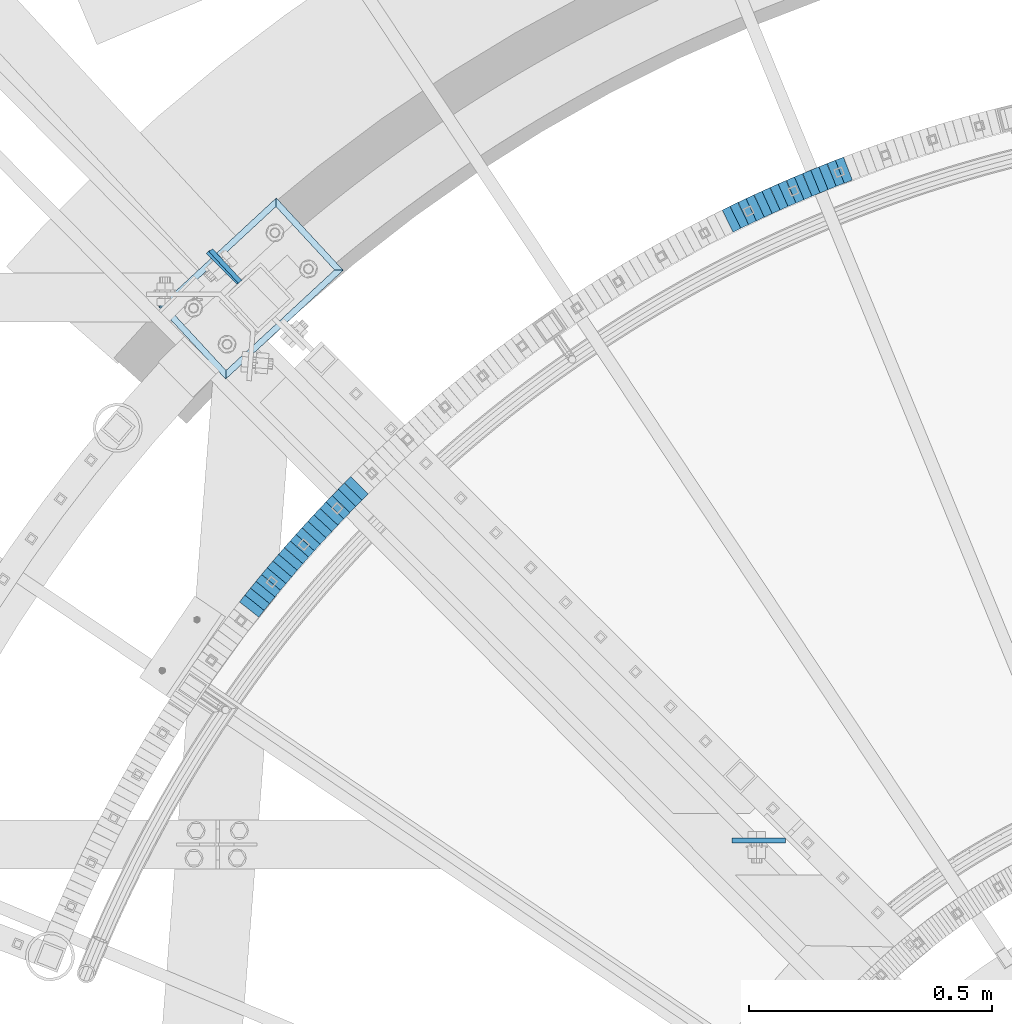
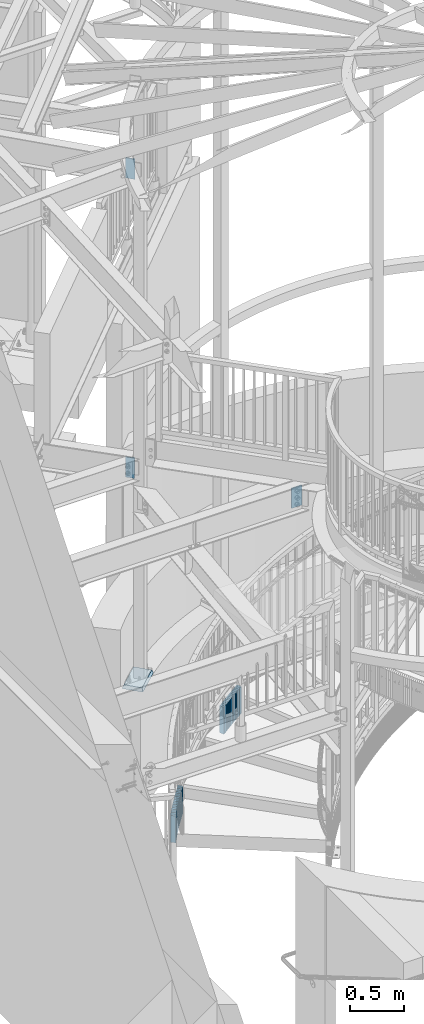
# One storey, part 892 of 975: 38 plates.
"""IFC2X3 building model written with IfcOpenShell, lengths in millimetres."""

from ifc_helpers import new_model, si_unit, frame, origin_with_axes, place, context, subcontext, project, spatial, faceted_brep, material, type_object, element, save


model = new_model("IFC2X3")

# Units and contexts
model_context = context("Model", 3, precision=1e-05, world=origin_with_axes())
body_context = subcontext(model_context, "Body", "Model", "MODEL_VIEW")
ifc_project = project(units=[si_unit("LENGTHUNIT", "METRE", prefix="MILLI"), si_unit("AREAUNIT", "SQUARE_METRE"), si_unit("VOLUMEUNIT", "CUBIC_METRE"), si_unit("MASSUNIT", "GRAM", prefix="KILO"), si_unit("TIMEUNIT", "SECOND"), si_unit("PLANEANGLEUNIT", "RADIAN"), si_unit("SOLIDANGLEUNIT", "STERADIAN"), si_unit("THERMODYNAMICTEMPERATUREUNIT", "DEGREE_CELSIUS"), si_unit("LUMINOUSINTENSITYUNIT", "LUMEN")], contexts=[model_context])

# Site, building, storey
site_placement = place(None, origin_with_axes())
site = spatial("IfcSite", under=ifc_project, at=site_placement, CompositionType="ELEMENT")
building_placement = place(site_placement, origin_with_axes())
building = spatial("IfcBuilding", under=site, at=building_placement, Name="Undefined", CompositionType="ELEMENT")
storey_placement = place(building_placement, origin_with_axes())
storey = spatial("IfcBuildingStorey", under=building, at=storey_placement, Name="Undefined", CompositionType="ELEMENT", Elevation=0.0)

# Plates
ifc_material_1 = material(Name="STEEL/A36")
plate_type_1 = type_object("IfcPlateType", PredefinedType="NOTDEFINED")
plate_1_placement = place(storey_placement, frame((33694.2841513362, 6079.05078259867, 728.399999991737), z_axis=(0.931899909597925, 0.362715533843505, 0.0), x_axis=(0.0, 0.0, -1.0)))
element("IfcPlate", 1, at=plate_1_placement, inside=storey, type_object=plate_type_1, material=ifc_material_1, Name="WALL", context=body_context, shape_type="Brep", body=[
    faceted_brep([(0.0, -25.3999999999724, -1.81898940354586e-11), (-5.80000019073486, -25.3999999999724, 17.9212169647508), (-5.80000019073486, 25.399999999885, 17.9212169646526), (0.0, 25.3999999999869, 1.45519152283669e-11), (299.0, -25.3999999999724, 17.9212169647508), (299.0, 25.399999999885, 17.9212169646526), (304.799987792969, -25.3999999999724, -1.81898940354586e-11), (304.799987792969, 25.3999999999869, 1.45519152283669e-11)], [[[0, 1, 2, 3]], [[1, 4, 5, 2]], [[4, 6, 7, 5]], [[6, 0, 3, 7]], [[5, 7, 3, 2]], [[6, 4, 1, 0]]]),
])
plate_2_placement = place(storey_placement, frame((33677.5841513301, 6072.55078259968, 722.699999991737), z_axis=(0.931899909597925, 0.362715533843505, 0.0), x_axis=(0.0, 0.0, -1.0)))
element("IfcPlate", 2, at=plate_2_placement, inside=storey, type_object=plate_type_1, material=ifc_material_1, Name="WALL", context=body_context, shape_type="Brep", body=[
    faceted_brep([(0.0, -25.3999999999724, -1.81898940354586e-11), (-5.69999980926514, -25.4000000000087, 17.9245643615468), (-5.69999980926514, 25.3999999999687, 17.9245643615541), (0.0, 25.3999999999869, 1.45519152283669e-11), (299.100006103516, -25.4000000000087, 17.9245643615468), (299.100006103516, 25.3999999999687, 17.9245643615541), (304.799987792969, -25.3999999999724, -1.81898940354586e-11), (304.799987792969, 25.3999999999869, 1.45519152283669e-11)], [[[0, 1, 2, 3]], [[1, 4, 5, 2]], [[4, 6, 7, 5]], [[6, 0, 3, 7]], [[5, 7, 3, 2]], [[6, 4, 1, 0]]]),
])
plate_3_placement = place(storey_placement, frame((33660.6904567118, 6065.73436197421, 716.999999991737), z_axis=(0.927316420402317, 0.374278314162379, 0.0), x_axis=(0.0, 0.0, -1.0)))
element("IfcPlate", 3, at=plate_3_placement, inside=storey, type_object=plate_type_1, material=ifc_material_1, Name="WALL", context=body_context, shape_type="Brep", body=[
    faceted_brep([(0.0, -25.3999999999724, -1.81898940354586e-11), (-5.69999980926514, -25.3999999999578, 17.9047489166387), (-5.69999980926514, 25.3999999999069, 17.9047489165732), (0.0, 25.3999999999869, 1.45519152283669e-11), (299.100006103516, -25.3999999999578, 17.9047489166387), (299.100006103516, 25.3999999999069, 17.9047489165732), (304.799987792969, -25.3999999999724, -1.81898940354586e-11), (304.799987792969, 25.3999999999869, 1.45519152283669e-11)], [[[0, 1, 2, 3]], [[1, 4, 5, 2]], [[4, 6, 7, 5]], [[6, 0, 3, 7]], [[5, 7, 3, 2]], [[6, 4, 1, 0]]]),
])
for number, where, z_axis, x_axis, name in (
    (4, (33643.9688259892, 6058.88490408454, 711.199999991737), (0.925369259401996, 0.379066925164674, 0.0), (0.0, 0.0, -1.0), "WALL"),
    (5, (33627.3688259861, 6052.08490408421, 705.399999991737), (0.925369259401996, 0.379066925164674, 0.0), (0.0, 0.0, -1.0), "WALL"),
):
    element("IfcPlate", number, at=place(storey_placement, frame(where, z_axis=z_axis, x_axis=x_axis)), inside=storey, type_object=plate_type_1, material=ifc_material_1, Name=name, context=body_context, shape_type="Brep", body=[
        faceted_brep([(0.0, -25.3999999999724, -1.81898940354586e-11), (-5.80000019073486, -25.3999999999869, 17.9387855530222), (-5.80000019073486, 25.3999999999469, 17.9387855528548), (0.0, 25.3999999999869, 1.45519152283669e-11), (299.0, -25.3999999999869, 17.9387855530222), (299.0, 25.3999999999469, 17.9387855528548), (304.799987792969, -25.3999999999724, -1.81898940354586e-11), (304.799987792969, 25.3999999999869, 1.45519152283669e-11)], [[[0, 1, 2, 3]], [[1, 4, 5, 2]], [[4, 6, 7, 5]], [[6, 0, 3, 7]], [[5, 7, 3, 2]], [[6, 4, 1, 0]]]),
    ])
for number, where, z_axis, x_axis, name in (
    (6, (33610.5771597716, 6044.96330215377, 699.699999991737), (0.920581781842572, 0.390549846933213, 0.0), (0.0, 0.0, -1.0), "WALL"),
    (7, (33594.0771597699, 6037.96330215338, 693.999999991737), (0.920581781842572, 0.390549846933213, 0.0), (0.0, 0.0, -1.0), "WALL"),
):
    element("IfcPlate", number, at=place(storey_placement, frame(where, z_axis=z_axis, x_axis=x_axis)), inside=storey, type_object=plate_type_1, material=ifc_material_1, Name=name, context=body_context, shape_type="Brep", body=[
        faceted_brep([(0.0, -25.3999999999724, -1.81898940354586e-11), (-5.69999980926514, -25.4000000000087, 17.9245643615468), (-5.69999980926514, 25.3999999999687, 17.9245643615541), (0.0, 25.3999999999869, 1.45519152283669e-11), (299.100006103516, -25.4000000000087, 17.9245643615468), (299.100006103516, 25.3999999999687, 17.9245643615541), (304.799987792969, -25.3999999999724, -1.81898940354586e-11), (304.799987792969, 25.3999999999869, 1.45519152283669e-11)], [[[0, 1, 2, 3]], [[1, 4, 5, 2]], [[4, 6, 7, 5]], [[6, 0, 3, 7]], [[5, 7, 3, 2]], [[6, 4, 1, 0]]]),
    ])
plate_4_placement = place(storey_placement, frame((33577.3865783012, 6030.63788326108, 688.199999991737), z_axis=(0.915644030049762, 0.401990062357556, -1.95650045498041e-10), x_axis=(0.0, 0.0, -1.0)))
element("IfcPlate", 8, at=plate_4_placement, inside=storey, type_object=plate_type_1, material=ifc_material_1, Name="WALL", context=body_context, shape_type="Brep", body=[
    faceted_brep([(0.0, -25.3999999999724, -1.81898940354586e-11), (-5.80000019073486, -25.4000000000415, 17.9067020416005), (-5.80000019073486, 25.3999999999396, 17.9067020415678), (0.0, 25.3999999999869, 1.45519152283669e-11), (299.0, -25.4000000000415, 17.9067020416005), (299.0, 25.3999999999396, 17.9067020415678), (304.799987792969, -25.3999999999724, -1.81898940354586e-11), (304.799987792969, 25.3999999999869, 1.45519152283669e-11)], [[[0, 1, 2, 3]], [[1, 4, 5, 2]], [[4, 6, 7, 5]], [[6, 0, 3, 7]], [[5, 7, 3, 2]], [[6, 4, 1, 0]]]),
])
plate_5_placement = place(storey_placement, frame((33560.9865782972, 6023.43788326146, 682.499999991737), z_axis=(0.915644030049762, 0.401990062357556, -1.95650045498041e-10), x_axis=(0.0, 0.0, -1.0)))
element("IfcPlate", 9, at=plate_5_placement, inside=storey, type_object=plate_type_1, material=ifc_material_1, Name="WALL", context=body_context, shape_type="Brep", body=[
    faceted_brep([(0.0, -25.3999999999724, -1.81898940354586e-11), (-5.69999980926514, -25.4000000000524, 17.9134025573221), (-5.69999980926514, 25.4000000000524, 17.9134025574494), (0.0, 25.3999999999869, 1.45519152283669e-11), (299.100006103516, -25.4000000000524, 17.9134025573221), (299.100006103516, 25.4000000000524, 17.9134025574494), (304.799987792969, -25.3999999999724, -1.81898940354586e-11), (304.799987792969, 25.3999999999869, 1.45519152283669e-11)], [[[0, 1, 2, 3]], [[1, 4, 5, 2]], [[4, 6, 7, 5]], [[6, 0, 3, 7]], [[5, 7, 3, 2]], [[6, 4, 1, 0]]]),
])
plate_6_placement = place(storey_placement, frame((33544.3972225924, 6015.90869021668, 676.699999991737), z_axis=(0.910557689794828, 0.413382018906854, 0.0), x_axis=(0.0, 0.0, -1.0)))
element("IfcPlate", 10, at=plate_6_placement, inside=storey, type_object=plate_type_1, material=ifc_material_1, Name="WALL", context=body_context, shape_type="Brep", body=[
    faceted_brep([(0.0, -25.3999999999724, -1.81898940354586e-11), (-5.80000019073486, -25.3999999999614, 17.8966484070224), (-5.80000019073486, 25.3999999999105, 17.896648406906), (0.0, 25.3999999999869, 1.45519152283669e-11), (299.0, -25.3999999999614, 17.8966484070224), (299.0, 25.3999999999105, 17.896648406906), (304.799987792969, -25.3999999999724, -1.81898940354586e-11), (304.799987792969, 25.3999999999869, 1.45519152283669e-11)], [[[0, 1, 2, 3]], [[1, 4, 5, 2]], [[4, 6, 7, 5]], [[6, 0, 3, 7]], [[5, 7, 3, 2]], [[6, 4, 1, 0]]]),
])
plate_7_placement = place(storey_placement, frame((33528.1435691843, 6008.48425708857, 670.999999991737), z_axis=(0.909595755817756, 0.415494357360392, 3.29607246385422e-10), x_axis=(0.0, 0.0, -1.0)))
element("IfcPlate", 11, at=plate_7_placement, inside=storey, type_object=plate_type_1, material=ifc_material_1, Name="WALL", context=body_context, shape_type="Brep", body=[
    faceted_brep([(0.0, -25.3999999999724, -1.81898940354586e-11), (-5.69999980926514, -25.4000000001106, 17.8134784697704), (-5.69999980926514, 25.4000000000306, 17.8134784698614), (0.0, 25.3999999999869, 1.45519152283669e-11), (299.100006103516, -25.4000000001106, 17.8134784697704), (299.100006103516, 25.4000000000306, 17.8134784698614), (304.799987792969, -25.3999999999724, -1.81898940354586e-11), (304.799987792969, 25.3999999999869, 1.45519152283669e-11)], [[[0, 1, 2, 3]], [[1, 4, 5, 2]], [[4, 6, 7, 5]], [[6, 0, 3, 7]], [[5, 7, 3, 2]], [[6, 4, 1, 0]]]),
])
plate_8_placement = place(storey_placement, frame((33511.709232515, 6000.77577129134, 665.299999991737), z_axis=(0.905324661295672, 0.424720211021181, 6.89760781824589e-11), x_axis=(0.0, 0.0, -1.0)))
element("IfcPlate", 12, at=plate_8_placement, inside=storey, type_object=plate_type_1, material=ifc_material_1, Name="WALL", context=body_context, shape_type="Brep", body=[
    faceted_brep([(0.0, -25.3999999999724, -1.81898940354586e-11), (-5.69999980926514, -25.4000000000087, 17.8910598754701), (-5.69999980926514, 25.4000000000087, 17.8910598755028), (0.0, 25.3999999999869, 1.45519152283669e-11), (299.100006103516, -25.4000000000087, 17.8910598754701), (299.100006103516, 25.4000000000087, 17.8910598755028), (304.799987792969, -25.3999999999724, -1.81898940354586e-11), (304.799987792969, 25.3999999999869, 1.45519152283669e-11)], [[[0, 1, 2, 3]], [[1, 4, 5, 2]], [[4, 6, 7, 5]], [[6, 0, 3, 7]], [[5, 7, 3, 2]], [[6, 4, 1, 0]]]),
])
plate_9_placement = place(storey_placement, frame((33495.5092325195, 5993.17577129076, 659.499999991737), z_axis=(0.905324661295672, 0.424720211021181, 6.89760781824589e-11), x_axis=(0.0, 0.0, -1.0)))
element("IfcPlate", 13, at=plate_9_placement, inside=storey, type_object=plate_type_1, material=ifc_material_1, Name="WALL", context=body_context, shape_type="Brep", body=[
    faceted_brep([(0.0, -25.3999999999724, -1.81898940354586e-11), (-5.80000019073486, -25.4000000000378, 17.8932952880568), (-5.80000019073486, 25.4000000001179, 17.8932952881351), (0.0, 25.3999999999869, 1.45519152283669e-11), (299.0, -25.4000000000378, 17.8932952880568), (299.0, 25.4000000001179, 17.8932952881351), (304.799987792969, -25.3999999999724, -1.81898940354586e-11), (304.799987792969, 25.3999999999869, 1.45519152283669e-11)], [[[0, 1, 2, 3]], [[1, 4, 5, 2]], [[4, 6, 7, 5]], [[6, 0, 3, 7]], [[5, 7, 3, 2]], [[6, 4, 1, 0]]]),
])
plate_10_placement = place(storey_placement, frame((33479.1227463276, 5985.23918009355, 653.799999991737), z_axis=(0.899947055070276, 0.435999195034048, 0.0), x_axis=(0.0, 0.0, -1.0)))
element("IfcPlate", 14, at=plate_10_placement, inside=storey, type_object=plate_type_1, material=ifc_material_1, Name="WALL", context=body_context, shape_type="Brep", body=[
    faceted_brep([(0.0, -25.3999999999724, -1.81898940354586e-11), (-5.69999980926514, -25.4000000000087, 17.8910598754701), (-5.69999980926514, 25.4000000000087, 17.8910598755028), (0.0, 25.3999999999869, 1.45519152283669e-11), (299.100006103516, -25.4000000000087, 17.8910598754701), (299.100006103516, 25.4000000000087, 17.8910598755028), (304.799987792969, -25.3999999999724, -1.81898940354586e-11), (304.799987792969, 25.3999999999869, 1.45519152283669e-11)], [[[0, 1, 2, 3]], [[1, 4, 5, 2]], [[4, 6, 7, 5]], [[6, 0, 3, 7]], [[5, 7, 3, 2]], [[6, 4, 1, 0]]]),
])
plate_11_placement = place(storey_placement, frame((33463.066788802, 5977.41198556887, 648.099999991737), z_axis=(0.898876404534364, 0.438202247108996, 8.72196324053222e-11), x_axis=(0.0, 0.0, -1.0)))
element("IfcPlate", 15, at=plate_11_placement, inside=storey, type_object=plate_type_1, material=ifc_material_1, Name="WALL", context=body_context, shape_type="Brep", body=[
    faceted_brep([(0.0, -25.3999999999724, -1.81898940354586e-11), (-5.69999980926514, -25.4000000000378, 17.8044929504049), (-5.69999980926514, 25.4000000000233, 17.8044929504613), (0.0, 25.3999999999869, 1.45519152283669e-11), (299.100006103516, -25.4000000000378, 17.8044929504049), (299.100006103516, 25.4000000000233, 17.8044929504613), (304.799987792969, -25.3999999999724, -1.81898940354586e-11), (304.799987792969, 25.3999999999869, 1.45519152283669e-11)], [[[0, 1, 2, 3]], [[1, 4, 5, 2]], [[4, 6, 7, 5]], [[6, 0, 3, 7]], [[5, 7, 3, 2]], [[6, 4, 1, 0]]]),
])
plate_12_placement = place(storey_placement, frame((32691.4366136415, 5420.04103714326, 344.099999991737), z_axis=(0.707106781186548, 0.707106781186548, 0.0), x_axis=(0.0, 0.0, -1.0)))
element("IfcPlate", 16, at=plate_12_placement, inside=storey, type_object=plate_type_1, material=ifc_material_1, Name="WALL", context=body_context, shape_type="Brep", body=[
    faceted_brep([(0.0, -25.3999999999724, -1.81898940354586e-11), (-5.69999980926514, -25.3999999999905, 17.9605121612622), (-5.69999980926514, 25.3999999999542, 17.9605121611967), (0.0, 25.3999999999869, 1.45519152283669e-11), (299.100006103516, -25.3999999999905, 17.9605121612622), (299.100006103516, 25.3999999999542, 17.9605121611967), (304.799987792969, -25.3999999999724, -1.81898940354586e-11), (304.799987792969, 25.3999999999869, 1.45519152283669e-11)], [[[0, 1, 2, 3]], [[1, 4, 5, 2]], [[4, 6, 7, 5]], [[6, 0, 3, 7]], [[5, 7, 3, 2]], [[6, 4, 1, 0]]]),
])
plate_13_placement = place(storey_placement, frame((32678.7249206485, 5407.02681907499, 338.399999991737), z_axis=(0.698672999098481, 0.715441150850812, -5.66315065952948e-11), x_axis=(0.0, 0.0, -1.0)))
element("IfcPlate", 17, at=plate_13_placement, inside=storey, type_object=plate_type_1, material=ifc_material_1, Name="WALL", context=body_context, shape_type="Brep", body=[
    faceted_brep([(0.0, -25.3999999999724, -1.81898940354586e-11), (-5.69999980926514, -25.4000000000087, 17.8910598754701), (-5.69999980926514, 25.4000000000087, 17.8910598755028), (0.0, 25.3999999999869, 1.45519152283669e-11), (299.100006103516, -25.4000000000087, 17.8910598754701), (299.100006103516, 25.4000000000087, 17.8910598755028), (304.799987792969, -25.3999999999724, -1.81898940354586e-11), (304.799987792969, 25.3999999999869, 1.45519152283669e-11)], [[[0, 1, 2, 3]], [[1, 4, 5, 2]], [[4, 6, 7, 5]], [[6, 0, 3, 7]], [[5, 7, 3, 2]], [[6, 4, 1, 0]]]),
])
plate_14_placement = place(storey_placement, frame((32666.224920648, 5394.22681907493, 332.599999991737), z_axis=(0.698672999098481, 0.715441150850812, -5.66315065952948e-11), x_axis=(0.0, 0.0, -1.0)))
element("IfcPlate", 18, at=plate_14_placement, inside=storey, type_object=plate_type_1, material=ifc_material_1, Name="WALL", context=body_context, shape_type="Brep", body=[
    faceted_brep([(0.0, -25.3999999999724, -1.81898940354586e-11), (-5.80000019073486, -25.4000000000378, 17.8932952880568), (-5.80000019073486, 25.4000000001179, 17.8932952881351), (0.0, 25.3999999999869, 1.45519152283669e-11), (299.0, -25.4000000000378, 17.8932952880568), (299.0, 25.4000000001179, 17.8932952881351), (304.799987792969, -25.3999999999724, -1.81898940354586e-11), (304.799987792969, 25.3999999999869, 1.45519152283669e-11)], [[[0, 1, 2, 3]], [[1, 4, 5, 2]], [[4, 6, 7, 5]], [[6, 0, 3, 7]], [[5, 7, 3, 2]], [[6, 4, 1, 0]]]),
])
plate_15_placement = place(storey_placement, frame((32653.6852384961, 5381.18264921557, 326.899999991737), z_axis=(0.692997020219925, 0.720940448280095, 1.13263922685292e-11), x_axis=(0.0, 0.0, -1.0)))
element("IfcPlate", 19, at=plate_15_placement, inside=storey, type_object=plate_type_1, material=ifc_material_1, Name="WALL", context=body_context, shape_type="Brep", body=[
    faceted_brep([(0.0, -25.3999999999724, -1.81898940354586e-11), (-5.69999980926514, -25.4000000000087, 17.8910598754701), (-5.69999980926514, 25.4000000000087, 17.8910598755028), (0.0, 25.3999999999869, 1.45519152283669e-11), (299.100006103516, -25.4000000000087, 17.8910598754701), (299.100006103516, 25.4000000000087, 17.8910598755028), (304.799987792969, -25.3999999999724, -1.81898940354586e-11), (304.799987792969, 25.3999999999869, 1.45519152283669e-11)], [[[0, 1, 2, 3]], [[1, 4, 5, 2]], [[4, 6, 7, 5]], [[6, 0, 3, 7]], [[5, 7, 3, 2]], [[6, 4, 1, 0]]]),
])
plate_16_placement = place(storey_placement, frame((32641.2467431682, 5368.03742547699, 321.099999991737), z_axis=(0.68727955022236, 0.726393020235017, 0.0), x_axis=(0.0, 0.0, -1.0)))
element("IfcPlate", 20, at=plate_16_placement, inside=storey, type_object=plate_type_1, material=ifc_material_1, Name="WALL", context=body_context, shape_type="Brep", body=[
    faceted_brep([(0.0, -25.3999999999724, -1.81898940354586e-11), (-5.80000019073486, -25.3999999999614, 17.8966484070224), (-5.80000019073486, 25.3999999999105, 17.896648406906), (0.0, 25.3999999999869, 1.45519152283669e-11), (299.0, -25.3999999999614, 17.8966484070224), (299.0, 25.3999999999105, 17.896648406906), (304.799987792969, -25.3999999999724, -1.81898940354586e-11), (304.799987792969, 25.3999999999869, 1.45519152283669e-11)], [[[0, 1, 2, 3]], [[1, 4, 5, 2]], [[4, 6, 7, 5]], [[6, 0, 3, 7]], [[5, 7, 3, 2]], [[6, 4, 1, 0]]]),
])
plate_17_placement = place(storey_placement, frame((32628.9094592778, 5354.79117625392, 315.399999991737), z_axis=(0.681521706462616, 0.73179789807042, 1.42966655403143e-10), x_axis=(0.0, 0.0, -1.0)))
element("IfcPlate", 21, at=plate_17_placement, inside=storey, type_object=plate_type_1, material=ifc_material_1, Name="WALL", context=body_context, shape_type="Brep", body=[
    faceted_brep([(0.0, -25.3999999999724, -1.81898940354586e-11), (-5.69999980926514, -25.3999999999578, 17.9047489166387), (-5.69999980926514, 25.3999999999069, 17.9047489165732), (0.0, 25.3999999999869, 1.45519152283669e-11), (299.100006103516, -25.3999999999578, 17.9047489166387), (299.100006103516, 25.3999999999069, 17.9047489165732), (304.799987792969, -25.3999999999724, -1.81898940354586e-11), (304.799987792969, 25.3999999999869, 1.45519152283669e-11)], [[[0, 1, 2, 3]], [[1, 4, 5, 2]], [[4, 6, 7, 5]], [[6, 0, 3, 7]], [[5, 7, 3, 2]], [[6, 4, 1, 0]]]),
])
plate_18_placement = place(storey_placement, frame((32616.7385799653, 5341.61475433813, 309.699999991737), z_axis=(0.678512969955015, 0.734588421909048, -9.16134013095869e-12), x_axis=(0.0, 0.0, -1.0)))
element("IfcPlate", 22, at=plate_18_placement, inside=storey, type_object=plate_type_1, material=ifc_material_1, Name="WALL", context=body_context, shape_type="Brep", body=[
    faceted_brep([(0.0, -25.3999999999724, -1.81898940354586e-11), (-5.69999980926514, -25.4000000000524, 17.8331146239652), (-5.69999980926514, 25.4000000000742, 17.8331146240998), (0.0, 25.3999999999869, 1.45519152283669e-11), (299.100006103516, -25.4000000000524, 17.8331146239652), (299.100006103516, 25.4000000000742, 17.8331146240998), (304.799987792969, -25.3999999999724, -1.81898940354586e-11), (304.799987792969, 25.3999999999869, 1.45519152283669e-11)], [[[0, 1, 2, 3]], [[1, 4, 5, 2]], [[4, 6, 7, 5]], [[6, 0, 3, 7]], [[5, 7, 3, 2]], [[6, 4, 1, 0]]]),
])
plate_19_placement = place(storey_placement, frame((32604.5734107281, 5328.3439304751, 303.899999991737), z_axis=(0.675724628076021, 0.737154140605289, 3.47004515788284e-10), x_axis=(0.0, 0.0, -1.0)))
element("IfcPlate", 23, at=plate_19_placement, inside=storey, type_object=plate_type_1, material=ifc_material_1, Name="WALL", context=body_context, shape_type="Brep", body=[
    faceted_brep([(0.0, -25.3999999999724, -1.81898940354586e-11), (-5.80000019073486, -25.4000000000415, 17.9067020416005), (-5.80000019073486, 25.3999999999396, 17.9067020415678), (0.0, 25.3999999999869, 1.45519152283669e-11), (299.0, -25.4000000000415, 17.9067020416005), (299.0, 25.3999999999396, 17.9067020415678), (304.799987792969, -25.3999999999724, -1.81898940354586e-11), (304.799987792969, 25.3999999999869, 1.45519152283669e-11)], [[[0, 1, 2, 3]], [[1, 4, 5, 2]], [[4, 6, 7, 5]], [[6, 0, 3, 7]], [[5, 7, 3, 2]], [[6, 4, 1, 0]]]),
])
plate_20_placement = place(storey_placement, frame((32592.4679965056, 5314.81711431947, 298.199999991737), z_axis=(0.666794859061833, 0.745241313890145, -3.81132849724964e-11), x_axis=(0.0, 0.0, -1.0)))
element("IfcPlate", 24, at=plate_20_placement, inside=storey, type_object=plate_type_1, material=ifc_material_1, Name="WALL", context=body_context, shape_type="Brep", body=[
    faceted_brep([(0.0, -25.3999999999724, -1.81898940354586e-11), (-5.69999980926514, -25.3999999999578, 17.853290557905), (-5.69999980926514, 25.4000000000124, 17.8532905578759), (0.0, 25.3999999999869, 1.45519152283669e-11), (299.100006103516, -25.3999999999578, 17.853290557905), (299.100006103516, 25.4000000000124, 17.8532905578759), (304.799987792969, -25.3999999999724, -1.81898940354586e-11), (304.799987792969, 25.3999999999869, 1.45519152283669e-11)], [[[0, 1, 2, 3]], [[1, 4, 5, 2]], [[4, 6, 7, 5]], [[6, 0, 3, 7]], [[5, 7, 3, 2]], [[6, 4, 1, 0]]]),
])
plate_21_placement = place(storey_placement, frame((32580.5051115619, 5301.34656747472, 292.499999991737), z_axis=(0.664017424017731, 0.747717099310198, 6.23699634161314e-11), x_axis=(0.0, 0.0, -1.0)))
element("IfcPlate", 25, at=plate_21_placement, inside=storey, type_object=plate_type_1, material=ifc_material_1, Name="WALL", context=body_context, shape_type="Brep", body=[
    faceted_brep([(0.0, -25.3999999999724, -1.81898940354586e-11), (-5.69999980926514, -25.4000000000087, 17.9245643615468), (-5.69999980926514, 25.3999999999687, 17.9245643615541), (0.0, 25.3999999999869, 1.45519152283669e-11), (299.100006103516, -25.4000000000087, 17.9245643615468), (299.100006103516, 25.3999999999687, 17.9245643615541), (304.799987792969, -25.3999999999724, -1.81898940354586e-11), (304.799987792969, 25.3999999999869, 1.45519152283669e-11)], [[[0, 1, 2, 3]], [[1, 4, 5, 2]], [[4, 6, 7, 5]], [[6, 0, 3, 7]], [[5, 7, 3, 2]], [[6, 4, 1, 0]]]),
])
plate_22_placement = place(storey_placement, frame((32568.6346477458, 5287.86688625104, 286.699999991737), z_axis=(0.660880367914142, 0.750491265309376, -1.74695060195518e-10), x_axis=(0.0, 0.0, -1.0)))
element("IfcPlate", 26, at=plate_22_placement, inside=storey, type_object=plate_type_1, material=ifc_material_1, Name="WALL", context=body_context, shape_type="Brep", body=[
    faceted_brep([(0.0, -25.3999999999724, -1.81898940354586e-11), (-5.80000019073486, -25.3999999999869, 17.8549709320232), (-5.80000019073486, 25.3999999999432, 17.8549709319796), (0.0, 25.3999999999869, 1.45519152283669e-11), (299.0, -25.3999999999869, 17.8549709320232), (299.0, 25.3999999999432, 17.8549709319796), (304.799987792969, -25.3999999999724, -1.81898940354586e-11), (304.799987792969, 25.3999999999869, 1.45519152283669e-11)], [[[0, 1, 2, 3]], [[1, 4, 5, 2]], [[4, 6, 7, 5]], [[6, 0, 3, 7]], [[5, 7, 3, 2]], [[6, 4, 1, 0]]]),
])
plate_23_placement = place(storey_placement, frame((32556.8321688626, 5274.13411759491, 280.999999991737), z_axis=(0.651716247784784, 0.75846287474953, 0.0), x_axis=(0.0, 0.0, -1.0)))
element("IfcPlate", 27, at=plate_23_placement, inside=storey, type_object=plate_type_1, material=ifc_material_1, Name="WALL", context=body_context, shape_type="Brep", body=[
    faceted_brep([(0.0, -25.3999999999724, -1.81898940354586e-11), (-5.69999980926514, -25.4000000000378, 17.8044929504049), (-5.69999980926514, 25.4000000000233, 17.8044929504613), (0.0, 25.3999999999869, 1.45519152283669e-11), (299.100006103516, -25.4000000000378, 17.8044929504049), (299.100006103516, 25.4000000000233, 17.8044929504613), (304.799987792969, -25.3999999999724, -1.81898940354586e-11), (304.799987792969, 25.3999999999869, 1.45519152283669e-11)], [[[0, 1, 2, 3]], [[1, 4, 5, 2]], [[4, 6, 7, 5]], [[6, 0, 3, 7]], [[5, 7, 3, 2]], [[6, 4, 1, 0]]]),
])
plate_24_placement = place(storey_placement, frame((32545.1719434992, 5260.46376869364, 275.299999991737), z_axis=(0.648946605962904, 0.760833952061308, 2.20675246964674e-11), x_axis=(0.0, 0.0, -1.0)))
element("IfcPlate", 28, at=plate_24_placement, inside=storey, type_object=plate_type_1, material=ifc_material_1, Name="WALL", context=body_context, shape_type="Brep", body=[
    faceted_brep([(0.0, -25.3999999999724, -1.81898940354586e-11), (-5.69999980926514, -25.4000000000233, 17.8807163238162), (-5.69999980926514, 25.400000000096, 17.8807163239253), (0.0, 25.3999999999869, 1.45519152283669e-11), (299.100006103516, -25.4000000000233, 17.8807163238162), (299.100006103516, 25.400000000096, 17.8807163239253), (304.799987792969, -25.3999999999724, -1.81898940354586e-11), (304.799987792969, 25.3999999999869, 1.45519152283669e-11)], [[[0, 1, 2, 3]], [[1, 4, 5, 2]], [[4, 6, 7, 5]], [[6, 0, 3, 7]], [[5, 7, 3, 2]], [[6, 4, 1, 0]]]),
])
plate_25_placement = place(storey_placement, frame((32533.5426285668, 5246.61094235613, 269.599999991737), z_axis=(0.642929821248529, 0.765925090951677, -7.05604179529472e-11), x_axis=(0.0, 0.0, -1.0)))
element("IfcPlate", 29, at=plate_25_placement, inside=storey, type_object=plate_type_1, material=ifc_material_1, Name="WALL", context=body_context, shape_type="Brep", body=[
    faceted_brep([(0.0, -25.3999999999724, -1.81898940354586e-11), (-5.69999980926514, -25.4000000000087, 17.8910598754701), (-5.69999980926514, 25.4000000000087, 17.8910598755028), (0.0, 25.3999999999869, 1.45519152283669e-11), (299.100006103516, -25.4000000000087, 17.8910598754701), (299.100006103516, 25.4000000000087, 17.8910598755028), (304.799987792969, -25.3999999999724, -1.81898940354586e-11), (304.799987792969, 25.3999999999869, 1.45519152283669e-11)], [[[0, 1, 2, 3]], [[1, 4, 5, 2]], [[4, 6, 7, 5]], [[6, 0, 3, 7]], [[5, 7, 3, 2]], [[6, 4, 1, 0]]]),
])
plate_26_placement = place(storey_placement, frame((32522.0426285668, 5232.91094235604, 263.799999991737), z_axis=(0.642929821248529, 0.765925090951677, -7.05604179529472e-11), x_axis=(0.0, 0.0, -1.0)))
element("IfcPlate", 30, at=plate_26_placement, inside=storey, type_object=plate_type_1, material=ifc_material_1, Name="WALL", context=body_context, shape_type="Brep", body=[
    faceted_brep([(0.0, -25.3999999999724, -1.81898940354586e-11), (-5.80000019073486, -25.4000000000378, 17.8932952880568), (-5.80000019073486, 25.4000000001179, 17.8932952881351), (0.0, 25.3999999999869, 1.45519152283669e-11), (299.0, -25.4000000000378, 17.8932952880568), (299.0, 25.4000000001179, 17.8932952881351), (304.799987792969, -25.3999999999724, -1.81898940354586e-11), (304.799987792969, 25.3999999999869, 1.45519152283669e-11)], [[[0, 1, 2, 3]], [[1, 4, 5, 2]], [[4, 6, 7, 5]], [[6, 0, 3, 7]], [[5, 7, 3, 2]], [[6, 4, 1, 0]]]),
])
plate_27_placement = place(storey_placement, frame((32510.5449568845, 5218.87251836708, 258.099999991737), z_axis=(0.633543049896048, 0.773707440786512, -1.7827460396802e-11), x_axis=(0.0, 0.0, -1.0)))
element("IfcPlate", 31, at=plate_27_placement, inside=storey, type_object=plate_type_1, material=ifc_material_1, Name="WALL", context=body_context, shape_type="Brep", body=[
    faceted_brep([(0.0, -25.3999999999724, -1.81898940354586e-11), (-5.69999980926514, -25.3999999999614, 17.8370399475461), (-5.69999980926514, 25.4000000000487, 17.8370399475571), (0.0, 25.3999999999869, 1.45519152283669e-11), (299.100006103516, -25.3999999999614, 17.8370399475461), (299.100006103516, 25.4000000000487, 17.8370399475571), (304.799987792969, -25.3999999999724, -1.81898940354586e-11), (304.799987792969, 25.3999999999869, 1.45519152283669e-11)], [[[0, 1, 2, 3]], [[1, 4, 5, 2]], [[4, 6, 7, 5]], [[6, 0, 3, 7]], [[5, 7, 3, 2]], [[6, 4, 1, 0]]]),
])
plate_28_placement = place(storey_placement, frame((32499.2750902856, 5204.98681466281, 252.399999991737), z_axis=(0.630168888016633, 0.77645809453948, -2.13457269637729e-10), x_axis=(0.0, 0.0, -1.0)))
element("IfcPlate", 32, at=plate_28_placement, inside=storey, type_object=plate_type_1, material=ifc_material_1, Name="WALL", context=body_context, shape_type="Brep", body=[
    faceted_brep([(0.0, -25.3999999999724, -1.81898940354586e-11), (-5.69999980926514, -25.399999999936, 17.7730140686435), (-5.69999980926514, 25.4000000000487, 17.7730140686363), (0.0, 25.3999999999869, 1.45519152283669e-11), (299.100006103516, -25.399999999936, 17.7730140686435), (299.100006103516, 25.4000000000487, 17.7730140686363), (304.799987792969, -25.3999999999724, -1.81898940354586e-11), (304.799987792969, 25.3999999999869, 1.45519152283669e-11)], [[[0, 1, 2, 3]], [[1, 4, 5, 2]], [[4, 6, 7, 5]], [[6, 0, 3, 7]], [[5, 7, 3, 2]], [[6, 4, 1, 0]]]),
])
plate_29_placement = place(storey_placement, frame((32487.9630581314, 5190.84777912117, 246.699999991737), z_axis=(0.624695047600639, 0.780868809406059, 1.82944404514274e-10), x_axis=(0.0, 0.0, -1.0)))
element("IfcPlate", 33, at=plate_29_placement, inside=storey, type_object=plate_type_1, material=ifc_material_1, Name="WALL", context=body_context, shape_type="Brep", body=[
    faceted_brep([(0.0, -25.3999999999724, -1.81898940354586e-11), (-5.69999980926514, -25.3999999999942, 17.9287471771386), (-5.69999980926514, 25.3999999999796, 17.9287471770876), (0.0, 25.3999999999869, 1.45519152283669e-11), (299.100006103516, -25.3999999999942, 17.9287471771386), (299.100006103516, 25.3999999999796, 17.9287471770876), (304.799987792969, -25.3999999999724, -1.81898940354586e-11), (304.799987792969, 25.3999999999869, 1.45519152283669e-11)], [[[0, 1, 2, 3]], [[1, 4, 5, 2]], [[4, 6, 7, 5]], [[6, 0, 3, 7]], [[5, 7, 3, 2]], [[6, 4, 1, 0]]]),
])
plate_30_placement = place(storey_placement, frame((32476.7938983235, 5176.76094101792, 240.899999991737), z_axis=(0.621276225268862, 0.78359163594035, -7.90359990787692e-11), x_axis=(0.0, 0.0, -1.0)))
element("IfcPlate", 34, at=plate_30_placement, inside=storey, type_object=plate_type_1, material=ifc_material_1, Name="WALL", context=body_context, shape_type="Brep", body=[
    faceted_brep([(0.0, -25.3999999999724, -1.81898940354586e-11), (-5.80000019073486, -25.4000000000524, 17.8675689696865), (-5.80000019073486, 25.4000000000888, 17.867568969803), (0.0, 25.3999999999869, 1.45519152283669e-11), (299.0, -25.4000000000524, 17.8675689696865), (299.0, 25.4000000000888, 17.867568969803), (304.799987792969, -25.3999999999724, -1.81898940354586e-11), (304.799987792969, 25.3999999999869, 1.45519152283669e-11)], [[[0, 1, 2, 3]], [[1, 4, 5, 2]], [[4, 6, 7, 5]], [[6, 0, 3, 7]], [[5, 7, 3, 2]], [[6, 4, 1, 0]]]),
])
plate_type_2 = type_object("IfcPlateType", PredefinedType="NOTDEFINED")
plate_31_placement = place(storey_placement, frame((32458.1266177974, 5852.20429297683, 7289.79999999999), z_axis=(-0.679313234053475, 0.733848438057757, 0.0), x_axis=(0.0, 0.0, -1.0)))
element("IfcPlate", 35, at=plate_31_placement, inside=storey, type_object=plate_type_2, material=ifc_material_1, Name="PLATE", context=body_context, shape_type="Brep", body=[
    faceted_brep([(0.0, -4.76250000000073, 0.0), (0.0, -4.76249999999982, 88.9000015258789), (0.0, 4.76249999999982, 88.9000015258789), (0.0, 4.76250000000073, 0.0), (228.600006103516, -4.76250000014988, 88.9000320433279), (228.600006103516, 4.76249999983702, 88.9000320433188), (228.599990844727, -4.76249999999982, 0.0), (228.599990844727, 4.76250000000027, -7.27595761418343e-12)], [[[0, 1, 2, 3]], [[1, 4, 5, 2]], [[4, 6, 7, 5]], [[6, 0, 3, 7]], [[5, 7, 3, 2]], [[6, 4, 1, 0]]]),
])
plate_type_3 = type_object("IfcPlateType", PredefinedType="NOTDEFINED")
plate_32_placement = place(storey_placement, frame((32455.8757443911, 5850.38836164133, 3898.89999995233), z_axis=(-0.709002820319972, 0.705205644318255, 0.0), x_axis=(0.0, 0.0, -1.0)))
element("IfcPlate", 36, at=plate_32_placement, inside=storey, type_object=plate_type_3, material=ifc_material_1, Name="PLATE", context=body_context, shape_type="Brep", body=[
    faceted_brep([(0.0, -4.76250000000073, 0.0), (0.0, -4.76249999997526, 90.4835891723706), (0.0, 4.76250000001892, 90.4835891723633), (0.0, 4.76250000000073, 0.0), (228.600006103516, -4.76249999997526, 90.4835891723706), (228.600006103516, 4.76250000001892, 90.4835891723633), (228.599990844727, -4.76249999999982, 0.0), (228.599990844727, 4.76250000000027, -7.27595761418343e-12)], [[[0, 1, 2, 3]], [[1, 4, 5, 2]], [[4, 6, 7, 5]], [[6, 0, 3, 7]], [[5, 7, 3, 2]], [[6, 4, 1, 0]]]),
])
plate_type_4 = type_object("IfcPlateType", PredefinedType="NOTDEFINED")
plate_33_placement = place(storey_placement, frame((33582.2838814223, 4700.58710937791, 3898.9), z_axis=(-0.999999999999998, 6.90000001668524e-08, 0.0), x_axis=(0.0, 0.0, -1.0)))
element("IfcPlate", 37, at=plate_33_placement, inside=storey, type_object=plate_type_4, material=ifc_material_1, Name="PLATE", context=body_context, shape_type="Brep", body=[
    faceted_brep([(0.0, -4.76250000000073, 0.0), (0.0, -4.76249999999982, 110.032661437988), (0.0, 4.76249999999982, 110.032661437988), (0.0, 4.76250000000073, 0.0), (228.600006103516, -4.76249999999982, 110.032661437988), (228.600006103516, 4.76249999999982, 110.032661437988), (228.599990844727, -4.76249999999982, 0.0), (228.599990844727, 4.76250000000027, -7.27595761418343e-12)], [[[0, 1, 2, 3]], [[1, 4, 5, 2]], [[4, 6, 7, 5]], [[6, 0, 3, 7]], [[5, 7, 3, 2]], [[6, 4, 1, 0]]]),
])
ifc_material_2 = material(Name="CONCRETE/GROUT")
plate_type_5 = type_object("IfcPlateType", PredefinedType="NOTDEFINED")
plate_34_placement = place(storey_placement, frame((32428.4834511757, 5651.70377031462, 1390.65), z_axis=(-0.679313234053475, 0.733848438057757, 0.0), x_axis=(0.733848438057782, 0.679313234053447, 0.0)))
element("IfcPlate", 38, at=plate_34_placement, inside=storey, type_object=plate_type_5, material=ifc_material_2, Name="GROUT", context=body_context, shape_type="Brep", body=[
    faceted_brep([(330.200012367033, 19.0500013667977, 203.199997417756), (1.09139364212751e-11, 19.05, 203.199996948282), (12.7000000020234, -19.0499999844749, 190.500000003405), (317.500000003602, -19.049999999379, 190.499999996773), (330.200012206657, 19.0500004884277, -1.48389517562464e-07), (317.499999999585, -19.0499999999586, 12.6999999966938), (12.6999999980108, -19.0499999989649, 12.7000000033258), (2.63382389675826e-07, 19.0500000000138, 0.0)], [[[0, 1, 2, 3]], [[4, 5, 6, 7]], [[5, 4, 0, 3]], [[6, 5, 3, 2]], [[7, 6, 2, 1]], [[4, 7, 1, 0]]]),
])

save(model, "model.ifc")
